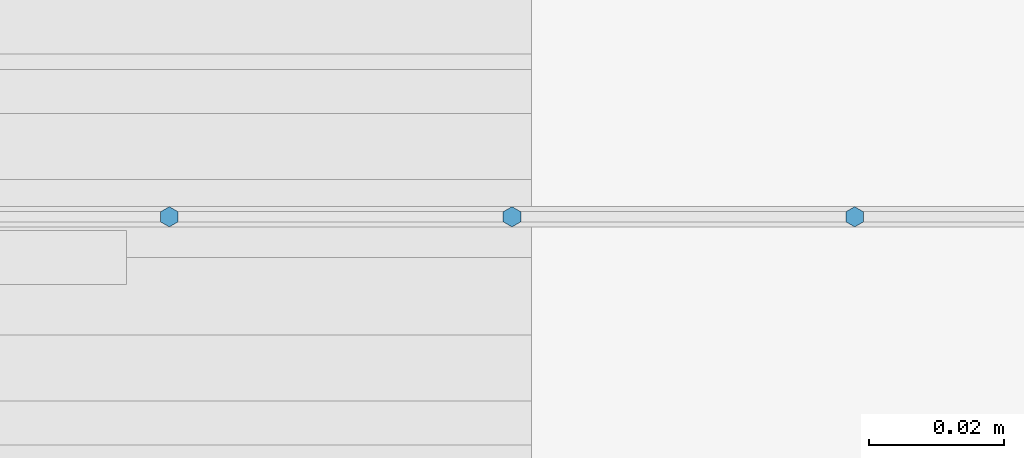
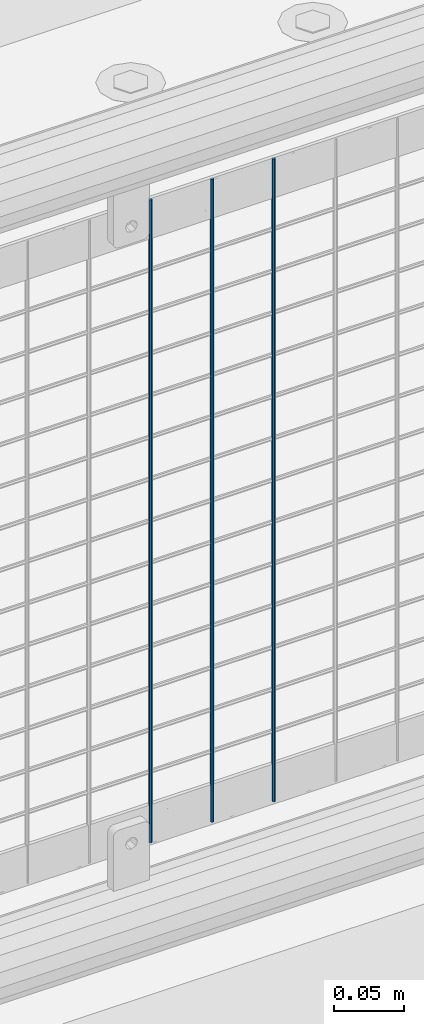
# One storey, part 80 of 270: 3 columns.
"""IFC2X3 building model written with IfcOpenShell, lengths in millimetres."""

from ifc_helpers import new_model, si_unit, frame, origin_with_axes, place, context, subcontext, project, spatial, faceted_brep, material, type_object, element, save


model = new_model("IFC2X3")

# Units and contexts
model_context = context("Model", 3, precision=1e-05, world=origin_with_axes())
body_context = subcontext(model_context, "Body", "Model", "MODEL_VIEW")
ifc_project = project(units=[si_unit("LENGTHUNIT", "METRE", prefix="MILLI"), si_unit("AREAUNIT", "SQUARE_METRE"), si_unit("VOLUMEUNIT", "CUBIC_METRE"), si_unit("MASSUNIT", "GRAM", prefix="KILO"), si_unit("TIMEUNIT", "SECOND"), si_unit("PLANEANGLEUNIT", "RADIAN"), si_unit("SOLIDANGLEUNIT", "STERADIAN"), si_unit("THERMODYNAMICTEMPERATUREUNIT", "DEGREE_CELSIUS"), si_unit("LUMINOUSINTENSITYUNIT", "LUMEN")], contexts=[model_context])

# Site, building, storey
site_placement = place(None, origin_with_axes())
site = spatial("IfcSite", under=ifc_project, at=site_placement, CompositionType="ELEMENT")
building_placement = place(site_placement, origin_with_axes())
building = spatial("IfcBuilding", under=site, at=building_placement, Name="Standard", CompositionType="ELEMENT")
storey_placement = place(building_placement, origin_with_axes())
storey = spatial("IfcBuildingStorey", under=building, at=storey_placement, Name="Undefined", CompositionType="ELEMENT", Elevation=0.0)

# Columns
ifc_material = material(Name="Misc_Undefined")
column_type = type_object("IfcColumnType", Name="D3", PredefinedType="NOTDEFINED")
for number, where, z_axis, x_axis in (
    (1, (6107.93, -16329.5, 353.02), (-1.0, 0.0, 0.0), (0.0, 0.0, 1.0)),
    (2, (6057.137, -16329.5, 353.02), (-1.0, 0.0, 0.0), (0.0, 0.0, 1.0)),
    (3, (6006.344, -16329.5, 353.02), (-1.0, 0.0, 0.0), (0.0, 0.0, 1.0)),
):
    element("IfcColumn", number, at=place(storey_placement, frame(where, z_axis=z_axis, x_axis=x_axis)), inside=storey, type_object=column_type, material=ifc_material, ObjectType="D3", context=body_context, shape_type="Brep", body=[
        faceted_brep([(0.0, -1.5, 0.0), (0.0, -0.75, -1.29903810567669), (560.0, -0.75, -1.29903810567703), (560.0, -1.5, 0.0), (0.0, 0.75, -1.29903810567669), (560.0, 0.75, -1.29903810567703), (0.0, 1.5, 0.0), (560.0, 1.5, 0.0), (0.0, 0.75, 1.29903810567669), (560.0, 0.75, 1.29903810567703), (0.0, -0.75, 1.29903810567669), (560.0, -0.75, 1.29903810567703)], [[[0, 1, 2, 3]], [[1, 4, 5, 2]], [[4, 6, 7, 5]], [[6, 8, 9, 7]], [[8, 10, 11, 9]], [[10, 0, 3, 11]], [[5, 7, 9, 11, 3, 2]], [[10, 8, 6, 4, 1, 0]]]),
    ])

save(model, "model.ifc")
